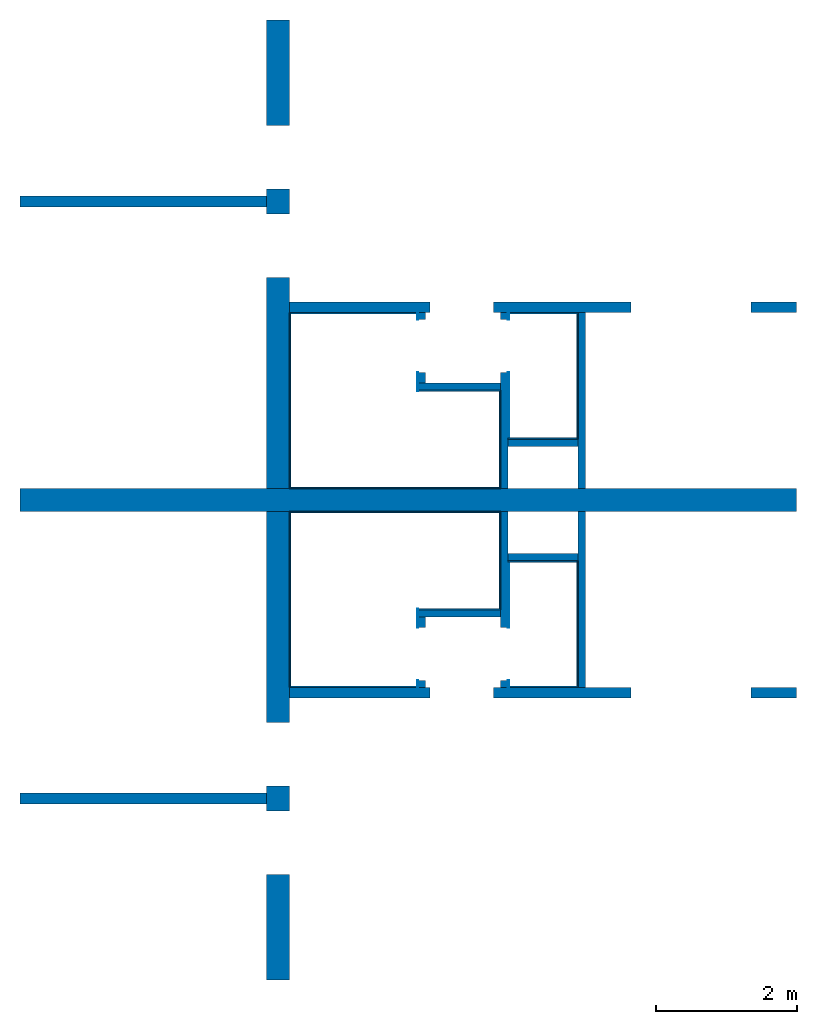
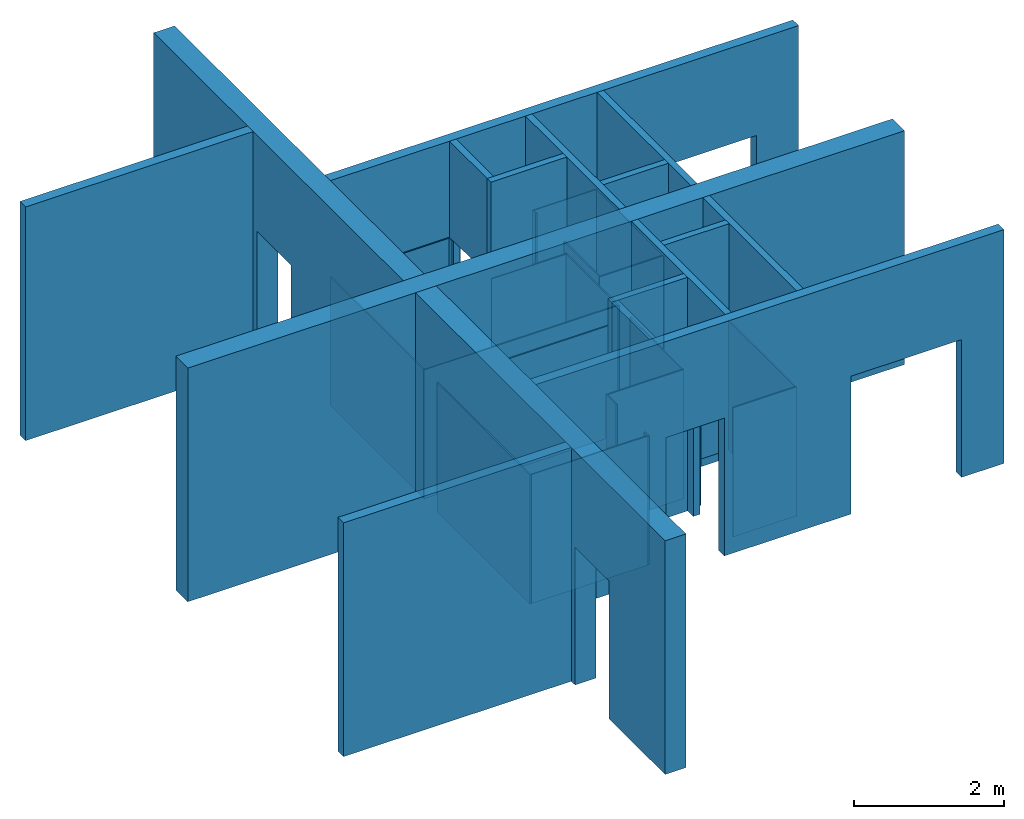
# One storey: 37 walls, 16 openings.
"""IFC2X3 building model written with IfcOpenShell, lengths in millimetres."""

from ifc_helpers import new_model, entity, si_unit, converted_unit, derived_unit, direction, frame, frame_2d, origin, origin_2d_with_axis, place, context, subcontext, project, spatial, rectangle, extrude, material, layer, layer_set, layer_usage, type_object, element, save


model = new_model("IFC2X3")

# Units and contexts
model_context = context("Model", 3, precision=0.01, world=origin(), true_north=direction((6.12303176911189e-17, 1.0)))
body_context = subcontext(model_context, "Body", "Model", "MODEL_VIEW")
ifc_project = project(units=[si_unit("LENGTHUNIT", "METRE", prefix="MILLI"), si_unit("AREAUNIT", "SQUARE_METRE"), si_unit("VOLUMEUNIT", "CUBIC_METRE"), converted_unit("PLANEANGLEUNIT", "DEGREE", entity("IfcRatioMeasure", 0.0174532925199433), si_unit("PLANEANGLEUNIT", "RADIAN"), dimensions=[0, 0, 0, 0, 0, 0, 0]), si_unit("MASSUNIT", "GRAM", prefix="KILO"), derived_unit("MASSDENSITYUNIT", [(si_unit("MASSUNIT", "GRAM", prefix="KILO"), 1), (si_unit("LENGTHUNIT", "METRE"), -3)]), si_unit("TIMEUNIT", "SECOND"), si_unit("FREQUENCYUNIT", "HERTZ"), si_unit("THERMODYNAMICTEMPERATUREUNIT", "DEGREE_CELSIUS"), derived_unit("THERMALTRANSMITTANCEUNIT", [(si_unit("MASSUNIT", "GRAM", prefix="KILO"), 1), (si_unit("THERMODYNAMICTEMPERATUREUNIT", "KELVIN"), -1), (si_unit("TIMEUNIT", "SECOND"), -3)]), derived_unit("VOLUMETRICFLOWRATEUNIT", [(si_unit("LENGTHUNIT", "METRE"), 3), (si_unit("TIMEUNIT", "SECOND"), -1)]), si_unit("ELECTRICCURRENTUNIT", "AMPERE"), si_unit("ELECTRICVOLTAGEUNIT", "VOLT"), si_unit("POWERUNIT", "WATT"), si_unit("FORCEUNIT", "NEWTON", prefix="KILO"), si_unit("ILLUMINANCEUNIT", "LUX"), si_unit("LUMINOUSFLUXUNIT", "LUMEN"), si_unit("LUMINOUSINTENSITYUNIT", "CANDELA"), derived_unit("USERDEFINED", [(si_unit("MASSUNIT", "GRAM", prefix="KILO"), -1), (si_unit("LENGTHUNIT", "METRE"), -2), (si_unit("TIMEUNIT", "SECOND"), 3), (si_unit("LUMINOUSFLUXUNIT", "LUMEN"), 1)]), derived_unit("LINEARVELOCITYUNIT", [(si_unit("LENGTHUNIT", "METRE"), 1), (si_unit("TIMEUNIT", "SECOND"), -1)]), si_unit("PRESSUREUNIT", "PASCAL"), derived_unit("USERDEFINED", [(si_unit("LENGTHUNIT", "METRE"), -2), (si_unit("MASSUNIT", "GRAM", prefix="KILO"), 1), (si_unit("TIMEUNIT", "SECOND"), -2)])], contexts=[model_context])

# Site, building, storey
site_placement = place(None, origin())
site = spatial("IfcSite", under=ifc_project, at=site_placement, CompositionType="ELEMENT")
building_placement = place(site_placement, origin())
building = spatial("IfcBuilding", under=site, at=building_placement, CompositionType="ELEMENT")
storey_placement = place(building_placement, frame((0.0, 0.0, 4000.0)))
storey = spatial("IfcBuildingStorey", under=building, at=storey_placement, Name="01 Level", CompositionType="ELEMENT", Elevation=4000.0)

# Wall
ifc_material_1 = material(Name="03")
ifc_layer_1 = layer(ifc_material_1, 12.5)
ifc_layer_2 = layer(ifc_material_1, 12.5)
ifc_material_2 = material(Name="04_Akustik Board")
ifc_layer_3 = layer(ifc_material_2, 100.0)
ifc_layer_4 = layer(ifc_material_1, 12.5)
ifc_layer_5 = layer(ifc_material_1, 12.5)
ifc_layer_set_1 = layer_set([ifc_layer_1, ifc_layer_2, ifc_layer_3, ifc_layer_4, ifc_layer_5], Name="Basic Wall:01_fal 150 mm - 2")
ifc_layer_usage_1 = layer_usage(ifc_layer_set_1, "AXIS2", "NEGATIVE", 75.0)
wall_type_1 = type_object("IfcWallType", Name="Basic Wall:01_fal 150 mm - 2", PredefinedType="STANDARD", material=ifc_layer_set_1)
wall_1_placement = place(storey_placement, frame((17483.4900708518, -73066.2395851399, -140.0)))
element("IfcWallStandardCase", 1, at=wall_1_placement, inside=storey, type_object=wall_type_1, material=ifc_layer_usage_1, Name="Basic Wall:01_fal 150 mm - 2", ObjectType="Basic Wall:01_fal 150 mm - 2", context=body_context, shape_type="SweptSolid", body=[
    extrude(rectangle(XDim=3500.00000000001, YDim=150.000000000001, at=frame_2d((1750.00000000001, 6.46593889541691e-13), x_axis=(-1.0, 0.0))), origin(), (0.0, 0.0, 1.0), 3800.0),
])

# Wall, openings
ifc_layer_usage_2 = layer_usage(ifc_layer_set_1, "AXIS2", "NEGATIVE", 75.0)
wall_2_placement = place(storey_placement, frame((21303.4900708518, -71566.2395851399, -140.0)))
wall_2 = element("IfcWallStandardCase", 2, at=wall_2_placement, inside=storey, type_object=wall_type_1, material=ifc_layer_usage_2, Name="Basic Wall:01_fal 150 mm - 2", ObjectType="Basic Wall:01_fal 150 mm - 2", context=body_context, shape_type="SweptSolid", body=[
    extrude(rectangle(XDim=7200.0, YDim=150.000000000001, at=frame_2d((3600.0, 1.81898940354586e-12), x_axis=(-1.0, 0.0))), origin(), (0.0, 0.0, 1.0), 3800.0),
])
opening_1_placement = place(wall_2_placement, frame((4850.0, -75.0, 0.0)))
element("IfcOpeningElement", 3, at=opening_1_placement, cuts=wall_2, Name="Basic Wall:01_fal 150 mm - 2", ObjectType="Opening", context=body_context, shape_type="SweptSolid", body=[
    extrude(rectangle(XDim=2240.0, YDim=1700.0, at=frame_2d((0.0, -2.1600499167107e-12), x_axis=(1.0, 0.0))), frame((850.0, 0.0, 1120.0), z_axis=(0.0, 1.0, 0.0), x_axis=(0.0, 0.0, -1.0)), (0.0, 0.0, 1.0), 150.000000000001),
])
opening_2_placement = place(wall_2_placement, frame((2000.0, -1449.0, 0.0)))
element("IfcOpeningElement", 4, at=opening_2_placement, cuts=wall_2, Name="Basic Wall:01_fal 150 mm - 2", ObjectType="Opening", context=body_context, shape_type="SweptSolid", body=[
    extrude(rectangle(XDim=2240.0, YDim=900.000000000003, at=frame_2d((-2.1600499167107e-12, 0.0), x_axis=(0.0, 1.0))), frame((450.0, 0.0, 1120.0), z_axis=(0.0, 1.0, 0.0), x_axis=(-1.0, 0.0, 0.0)), (0.0, 0.0, 1.0), 3048.0),
])

# Wall
ifc_layer_usage_3 = layer_usage(ifc_layer_set_1, "AXIS2", "POSITIVE", -75.0)
wall_3_placement = place(storey_placement, frame((17483.4900708518, -64596.2395851399, -140.0)))
element("IfcWallStandardCase", 5, at=wall_3_placement, inside=storey, type_object=wall_type_1, material=ifc_layer_usage_3, Name="Basic Wall:01_fal 150 mm - 2", ObjectType="Basic Wall:01_fal 150 mm - 2", context=body_context, shape_type="SweptSolid", body=[
    extrude(rectangle(XDim=3500.00000000003, YDim=150.000000000001, at=frame_2d((1750.00000000002, 1.27897692436818e-12), x_axis=(-1.0, 0.0))), origin(), (0.0, 0.0, 1.0), 3800.0),
])

# Wall, openings
ifc_layer_usage_4 = layer_usage(ifc_layer_set_1, "AXIS2", "POSITIVE", -75.0)
wall_4_placement = place(storey_placement, frame((21303.4900708518, -66096.2395851399, -140.0)))
wall_4 = element("IfcWallStandardCase", 6, at=wall_4_placement, inside=storey, type_object=wall_type_1, material=ifc_layer_usage_4, Name="Basic Wall:01_fal 150 mm - 2", ObjectType="Basic Wall:01_fal 150 mm - 2", context=body_context, shape_type="SweptSolid", body=[
    extrude(rectangle(XDim=7199.99999999998, YDim=150.000000000001, at=frame_2d((3599.99999999999, -1.69819713846664e-12), x_axis=(-1.0, 0.0))), origin(), (0.0, 0.0, 1.0), 3800.0),
])
opening_3_placement = place(wall_4_placement, frame((4850.0, -75.0, 0.0)))
element("IfcOpeningElement", 7, at=opening_3_placement, cuts=wall_4, Name="Basic Wall:01_fal 150 mm - 2", ObjectType="Opening", context=body_context, shape_type="SweptSolid", body=[
    extrude(rectangle(XDim=2240.0, YDim=1700.0, at=frame_2d((0.0, -2.1600499167107e-12), x_axis=(1.0, 0.0))), frame((850.0, 0.0, 1120.0), z_axis=(0.0, 1.0, 0.0), x_axis=(0.0, 0.0, -1.0)), (0.0, 0.0, 1.0), 150.000000000001),
])
opening_4_placement = place(wall_4_placement, frame((2000.0, -1599.0, 0.0)))
element("IfcOpeningElement", 8, at=opening_4_placement, cuts=wall_4, Name="Basic Wall:01_fal 150 mm - 2", ObjectType="Opening", context=body_context, shape_type="SweptSolid", body=[
    extrude(rectangle(XDim=2240.0, YDim=900.000000000003, at=frame_2d((-2.1600499167107e-12, 0.0), x_axis=(0.0, 1.0))), frame((450.0, 0.0, 1120.0), z_axis=(0.0, 1.0, 0.0), x_axis=(-1.0, 0.0, 0.0)), (0.0, 0.0, 1.0), 3048.0),
])

ifc_material_3 = material(Name="03")
ifc_layer_6 = layer(ifc_material_3, 10.0)
ifc_material_4 = material()
ifc_layer_7 = layer(ifc_material_4, 300.0)
ifc_layer_8 = layer(ifc_material_3, 10.0)
ifc_layer_set_2 = layer_set([ifc_layer_6, ifc_layer_7, ifc_layer_8], Name="Basic Wall:01_fal 300 mm")
ifc_layer_usage_5 = layer_usage(ifc_layer_set_2, "AXIS2", "NEGATIVE", 160.0)
wall_type_2 = type_object("IfcWallType", Name="Basic Wall:01_fal 300 mm", PredefinedType="STANDARD", material=ifc_layer_set_2)
wall_5_placement = place(storey_placement, frame((21143.4900708518, -68991.2395851399, -140.0), z_axis=(0.0, 0.0, 1.0), x_axis=(0.0, -1.0, 0.0)))
wall_5 = element("IfcWallStandardCase", 9, at=wall_5_placement, inside=storey, type_object=wall_type_2, material=ifc_layer_usage_5, Name="Basic Wall:01_fal 300 mm", ObjectType="Basic Wall:01_fal 300 mm", context=body_context, shape_type="SweptSolid", body=[
    extrude(rectangle(XDim=6650.0, YDim=319.999999999997, at=frame_2d((3325.0, -3.83693077310454e-13), x_axis=(-1.0, 0.0))), origin(), (0.0, 0.0, 1.0), 3800.0),
])
opening_5_placement = place(wall_5_placement, frame((3900.0, -1364.0, 0.0), z_axis=(0.0, 0.0, 1.0), x_axis=(0.0, 1.0, 0.0)))
element("IfcOpeningElement", 10, at=opening_5_placement, cuts=wall_5, Name="Basic Wall:01_fal 300 mm", ObjectType="Opening", context=body_context, shape_type="SweptSolid", body=[
    extrude(rectangle(XDim=2240.0, YDim=900.000000000003, at=origin_2d_with_axis()), frame((0.0, 450.0, 1120.0), z_axis=(1.0, 0.0, 0.0), x_axis=(0.0, 0.0, 1.0)), (0.0, 0.0, 1.0), 3048.0),
])
opening_6_placement = place(wall_5_placement, frame((5150.0, -1364.0, 0.0), z_axis=(0.0, 0.0, 1.0), x_axis=(0.0, 1.0, 0.0)))
element("IfcOpeningElement", 11, at=opening_6_placement, cuts=wall_5, Name="Basic Wall:01_fal 300 mm", ObjectType="Opening", context=body_context, shape_type="SweptSolid", body=[
    extrude(rectangle(XDim=2240.0, YDim=900.000000000003, at=frame_2d((0.0, 0.0), x_axis=(0.0, 1.0))), frame((0.0, 450.0, 1120.0), z_axis=(1.0, 0.0, 0.0), x_axis=(0.0, 1.0, 0.0)), (0.0, 0.0, 1.0), 3048.0),
])

# Wall
ifc_layer_usage_6 = layer_usage(ifc_layer_set_2, "AXIS2", "NEGATIVE", 160.0)
wall_6_placement = place(storey_placement, frame((17483.4900708518, -68831.2395851399, -140.0)))
element("IfcWallStandardCase", 12, at=wall_6_placement, inside=storey, type_object=wall_type_2, material=ifc_layer_usage_6, Name="Basic Wall:01_fal 300 mm", ObjectType="Basic Wall:01_fal 300 mm", context=body_context, shape_type="SweptSolid", body=[
    extrude(rectangle(XDim=11020.0, YDim=319.999999999997, at=frame_2d((5510.00000000001, -3.12638803734444e-13), x_axis=(-1.0, 0.0))), origin(), (0.0, 0.0, 1.0), 3800.0),
])

# Wall, openings
ifc_layer_usage_7 = layer_usage(ifc_layer_set_2, "AXIS2", "POSITIVE", -160.0)
wall_7_placement = place(storey_placement, frame((21143.4900708518, -68671.2395851399, -140.0), z_axis=(0.0, 0.0, 1.0), x_axis=(0.0, 1.0, 0.0)))
wall_7 = element("IfcWallStandardCase", 13, at=wall_7_placement, inside=storey, type_object=wall_type_2, material=ifc_layer_usage_7, Name="Basic Wall:01_fal 300 mm", ObjectType="Basic Wall:01_fal 300 mm", context=body_context, shape_type="SweptSolid", body=[
    extrude(rectangle(XDim=6649.99999999998, YDim=319.999999999997, at=frame_2d((3324.99999999999, 1.00897068477934e-12), x_axis=(-1.0, 0.0))), origin(), (0.0, 0.0, 1.0), 3800.0),
])
opening_7_placement = place(wall_7_placement, frame((3000.0, 1364.0, 0.0), z_axis=(0.0, 0.0, 1.0), x_axis=(0.0, -1.0, 0.0)))
element("IfcOpeningElement", 14, at=opening_7_placement, cuts=wall_7, Name="Basic Wall:01_fal 300 mm", ObjectType="Opening", context=body_context, shape_type="SweptSolid", body=[
    extrude(rectangle(XDim=2240.0, YDim=900.000000000003, at=origin_2d_with_axis()), frame((3048.0, 450.0, 1120.0), z_axis=(-1.0, 0.0, 0.0), x_axis=(0.0, 0.0, 1.0)), (0.0, 0.0, 1.0), 3048.0),
])
opening_8_placement = place(wall_7_placement, frame((4250.0, 1364.0, 0.0), z_axis=(0.0, 0.0, 1.0), x_axis=(0.0, -1.0, 0.0)))
element("IfcOpeningElement", 15, at=opening_8_placement, cuts=wall_7, Name="Basic Wall:01_fal 300 mm", ObjectType="Opening", context=body_context, shape_type="SweptSolid", body=[
    extrude(rectangle(XDim=2240.0, YDim=900.000000000003, at=frame_2d((0.0, 0.0), x_axis=(0.0, 1.0))), frame((3048.0, 450.0, 1120.0), z_axis=(-1.0, 0.0, 0.0), x_axis=(0.0, -1.0, 0.0)), (0.0, 0.0, 1.0), 3048.0),
])

# Wall, opening
ifc_layer_9 = layer(ifc_material_1, 12.5)
ifc_layer_10 = layer(ifc_material_2, 75.0)
ifc_layer_11 = layer(ifc_material_1, 12.5)
ifc_layer_set_3 = layer_set([ifc_layer_9, ifc_layer_10, ifc_layer_11], Name="Basic Wall:01_fal 100 mm - 1")
ifc_layer_usage_8 = layer_usage(ifc_layer_set_3, "AXIS2", "NEGATIVE", 50.0)
wall_type_3 = type_object("IfcWallType", Name="Basic Wall:01_fal 100 mm - 1", PredefinedType="STANDARD", material=ifc_layer_set_3)
wall_8_placement = place(storey_placement, frame((24353.4900708518, -71491.2395851399, -140.0), z_axis=(0.0, 0.0, 1.0), x_axis=(0.0, 1.0, 0.0)))
wall_8 = element("IfcWallStandardCase", 16, at=wall_8_placement, inside=storey, type_object=wall_type_3, material=ifc_layer_usage_8, Name="Basic Wall:01_fal 100 mm - 1", ObjectType="Basic Wall:01_fal 100 mm - 1", context=body_context, shape_type="SweptSolid", body=[
    extrude(rectangle(XDim=2499.99999999999, YDim=100.000000000003, at=frame_2d((1250.0, 2.66453525910038e-13), x_axis=(-1.0, 0.0))), origin(), (0.0, 0.0, 1.0), 3800.0),
])
opening_9_placement = place(wall_8_placement, frame((100.0, 1574.0, 0.0), z_axis=(0.0, 0.0, 1.0), x_axis=(0.0, -1.0, 0.0)))
element("IfcOpeningElement", 17, at=opening_9_placement, cuts=wall_8, Name="Basic Wall:01_fal 100 mm - 1", ObjectType="Opening", context=body_context, shape_type="SweptSolid", body=[
    extrude(rectangle(XDim=2240.0, YDim=750.000000000003, at=frame_2d((0.0, 0.0), x_axis=(0.0, 1.0))), frame((3048.0, 375.0, 1120.0), z_axis=(-1.0, 0.0, 0.0), x_axis=(0.0, -1.0, 0.0)), (0.0, 0.0, 1.0), 3048.0),
])

# Walls
ifc_layer_usage_9 = layer_usage(ifc_layer_set_3, "AXIS2", "NEGATIVE", 50.0)
wall_9_placement = place(storey_placement, frame((25453.4900708518, -71491.2395851399, -140.0), z_axis=(0.0, 0.0, 1.0), x_axis=(0.0, 1.0, 0.0)))
element("IfcWallStandardCase", 18, at=wall_9_placement, inside=storey, type_object=wall_type_3, material=ifc_layer_usage_9, Name="Basic Wall:01_fal 100 mm - 1", ObjectType="Basic Wall:01_fal 100 mm - 1", context=body_context, shape_type="SweptSolid", body=[
    extrude(rectangle(XDim=2499.99999999999, YDim=100.000000000003, at=frame_2d((1249.99999999999, 2.66453525910038e-13), x_axis=(-1.0, 0.0))), origin(), (0.0, 0.0, 1.0), 3800.0),
])
ifc_layer_usage_10 = layer_usage(ifc_layer_set_3, "AXIS2", "NEGATIVE", 50.0)
wall_10_placement = place(storey_placement, frame((24403.4900708518, -69641.2395851399, -140.0)))
element("IfcWallStandardCase", 19, at=wall_10_placement, inside=storey, type_object=wall_type_3, material=ifc_layer_usage_10, Name="Basic Wall:01_fal 100 mm - 1", ObjectType="Basic Wall:01_fal 100 mm - 1", context=body_context, shape_type="SweptSolid", body=[
    extrude(rectangle(XDim=1000.0, YDim=99.9999999999946, at=frame_2d((500.000000000001, 0.0), x_axis=(-1.0, 0.0))), origin(), (0.0, 0.0, 1.0), 3800.0),
])

# Wall, opening
ifc_layer_usage_11 = layer_usage(ifc_layer_set_3, "AXIS2", "POSITIVE", -50.0)
wall_11_placement = place(storey_placement, frame((24353.4900708518, -66171.2395851399, -140.0), z_axis=(0.0, 0.0, 1.0), x_axis=(0.0, -1.0, 0.0)))
wall_11 = element("IfcWallStandardCase", 20, at=wall_11_placement, inside=storey, type_object=wall_type_3, material=ifc_layer_usage_11, Name="Basic Wall:01_fal 100 mm - 1", ObjectType="Basic Wall:01_fal 100 mm - 1", context=body_context, shape_type="SweptSolid", body=[
    extrude(rectangle(XDim=2499.99999999998, YDim=100.000000000003, at=frame_2d((1249.99999999999, 7.95807864051312e-13), x_axis=(-1.0, 0.0))), origin(), (0.0, 0.0, 1.0), 3800.0),
])
opening_10_placement = place(wall_11_placement, frame((850.0, -1574.0, 0.0), z_axis=(0.0, 0.0, 1.0), x_axis=(0.0, 1.0, 0.0)))
element("IfcOpeningElement", 21, at=opening_10_placement, cuts=wall_11, Name="Basic Wall:01_fal 100 mm - 1", ObjectType="Opening", context=body_context, shape_type="SweptSolid", body=[
    extrude(rectangle(XDim=2240.0, YDim=750.000000000003, at=frame_2d((0.0, 0.0), x_axis=(0.0, 1.0))), frame((0.0, 375.0, 1120.0), z_axis=(1.0, 0.0, 0.0), x_axis=(0.0, 1.0, 0.0)), (0.0, 0.0, 1.0), 3048.0),
])

# Walls
ifc_layer_usage_12 = layer_usage(ifc_layer_set_3, "AXIS2", "POSITIVE", -50.0)
wall_12_placement = place(storey_placement, frame((25453.4900708518, -66171.2395851399, -140.0), z_axis=(0.0, 0.0, 1.0), x_axis=(0.0, -1.0, 0.0)))
element("IfcWallStandardCase", 22, at=wall_12_placement, inside=storey, type_object=wall_type_3, material=ifc_layer_usage_12, Name="Basic Wall:01_fal 100 mm - 1", ObjectType="Basic Wall:01_fal 100 mm - 1", context=body_context, shape_type="SweptSolid", body=[
    extrude(rectangle(XDim=2499.99999999999, YDim=100.000000000003, at=frame_2d((1249.99999999999, 7.95807864051312e-13), x_axis=(-1.0, 0.0))), origin(), (0.0, 0.0, 1.0), 3800.0),
])
ifc_layer_usage_13 = layer_usage(ifc_layer_set_3, "AXIS2", "POSITIVE", -50.0)
wall_13_placement = place(storey_placement, frame((24403.4900708518, -68021.2395851399, -140.0)))
element("IfcWallStandardCase", 23, at=wall_13_placement, inside=storey, type_object=wall_type_3, material=ifc_layer_usage_13, Name="Basic Wall:01_fal 100 mm - 1", ObjectType="Basic Wall:01_fal 100 mm - 1", context=body_context, shape_type="SweptSolid", body=[
    extrude(rectangle(XDim=1000.0, YDim=99.9999999999946, at=frame_2d((500.000000000001, -1.30384592011978e-12), x_axis=(-1.0, 0.0))), origin(), (0.0, 0.0, 1.0), 3800.0),
])
ifc_layer_usage_14 = layer_usage(ifc_layer_set_3, "AXIS2", "NEGATIVE", 50.0)
wall_14_placement = place(storey_placement, frame((24303.4900708518, -70441.2395851399, -140.0), z_axis=(0.0, 0.0, 1.0), x_axis=(-1.0, 0.0, 0.0)))
element("IfcWallStandardCase", 24, at=wall_14_placement, inside=storey, type_object=wall_type_3, material=ifc_layer_usage_14, Name="Basic Wall:01_fal 100 mm - 1", ObjectType="Basic Wall:01_fal 100 mm - 1", context=body_context, shape_type="SweptSolid", body=[
    extrude(rectangle(XDim=1167.5, YDim=99.9999999999946, at=frame_2d((583.749999999999, 0.0), x_axis=(-1.0, 0.0))), origin(), (0.0, 0.0, 1.0), 3800.0),
])

# Wall, opening
ifc_layer_usage_15 = layer_usage(ifc_layer_set_3, "AXIS2", "NEGATIVE", 50.0)
wall_15_placement = place(storey_placement, frame((23185.9900708518, -70491.2395851399, -140.0), z_axis=(0.0, 0.0, 1.0), x_axis=(0.0, -1.0, 0.0)))
wall_15 = element("IfcWallStandardCase", 25, at=wall_15_placement, inside=storey, type_object=wall_type_3, material=ifc_layer_usage_15, Name="Basic Wall:01_fal 100 mm - 1", ObjectType="Basic Wall:01_fal 100 mm - 1", context=body_context, shape_type="SweptSolid", body=[
    extrude(rectangle(XDim=999.999999999981, YDim=100.000000000003, at=frame_2d((499.99999999999, 0.0), x_axis=(-1.0, 0.0))), origin(), (0.0, 0.0, 1.0), 3800.0),
])
opening_11_placement = place(wall_15_placement, frame((900.0, -1474.0, 0.0), z_axis=(0.0, 0.0, 1.0), x_axis=(0.0, 1.0, 0.0)))
element("IfcOpeningElement", 26, at=opening_11_placement, cuts=wall_15, Name="Basic Wall:01_fal 100 mm - 1", ObjectType="Opening", context=body_context, shape_type="SweptSolid", body=[
    extrude(rectangle(XDim=2240.0, YDim=750.000000000003, at=origin_2d_with_axis()), frame((0.0, 375.0, 1120.0), z_axis=(1.0, 0.0, 0.0), x_axis=(0.0, 0.0, 1.0)), (0.0, 0.0, 1.0), 3048.0),
])

# Wall
ifc_layer_usage_16 = layer_usage(ifc_layer_set_3, "AXIS2", "POSITIVE", -50.0)
wall_16_placement = place(storey_placement, frame((24303.4900708518, -67221.2395851399, -140.0), z_axis=(0.0, 0.0, 1.0), x_axis=(-1.0, 0.0, 0.0)))
element("IfcWallStandardCase", 27, at=wall_16_placement, inside=storey, type_object=wall_type_3, material=ifc_layer_usage_16, Name="Basic Wall:01_fal 100 mm - 1", ObjectType="Basic Wall:01_fal 100 mm - 1", context=body_context, shape_type="SweptSolid", body=[
    extrude(rectangle(XDim=1167.50000000001, YDim=99.9999999999946, at=frame_2d((583.750000000004, -7.99360577730113e-13), x_axis=(-1.0, 0.0))), origin(), (0.0, 0.0, 1.0), 3800.0),
])

# Wall, opening
ifc_layer_usage_17 = layer_usage(ifc_layer_set_3, "AXIS2", "POSITIVE", -50.0)
wall_17_placement = place(storey_placement, frame((23185.9900708518, -67171.2395851399, -140.0), z_axis=(0.0, 0.0, 1.0), x_axis=(0.0, 1.0, 0.0)))
wall_17 = element("IfcWallStandardCase", 28, at=wall_17_placement, inside=storey, type_object=wall_type_3, material=ifc_layer_usage_17, Name="Basic Wall:01_fal 100 mm - 1", ObjectType="Basic Wall:01_fal 100 mm - 1", context=body_context, shape_type="SweptSolid", body=[
    extrude(rectangle(XDim=999.999999999955, YDim=100.000000000003, at=frame_2d((499.999999999977, -1.30739863379858e-12), x_axis=(-1.0, 0.0))), origin(), (0.0, 0.0, 1.0), 3800.0),
])
opening_12_placement = place(wall_17_placement, frame((150.0, 1474.0, 0.0), z_axis=(0.0, 0.0, 1.0), x_axis=(0.0, -1.0, 0.0)))
element("IfcOpeningElement", 29, at=opening_12_placement, cuts=wall_17, Name="Basic Wall:01_fal 100 mm - 1", ObjectType="Opening", context=body_context, shape_type="SweptSolid", body=[
    extrude(rectangle(XDim=2240.0, YDim=750.000000000003, at=origin_2d_with_axis()), frame((3048.0, 375.0, 1120.0), z_axis=(-1.0, 0.0, 0.0), x_axis=(0.0, 0.0, 1.0)), (0.0, 0.0, 1.0), 3048.0),
])

ifc_material_5 = material(Name="07")
ifc_layer_12 = layer(ifc_material_5, 15.0)
ifc_material_6 = material(Name="06")
ifc_layer_13 = layer(ifc_material_6, 5.0)
ifc_layer_set_4 = layer_set([ifc_layer_12, ifc_layer_13], Name="Basic Wall:01")
ifc_layer_usage_18 = layer_usage(ifc_layer_set_4, "AXIS2", "NEGATIVE", 10.0)
wall_type_4 = type_object("IfcWallType", Name="Basic Wall:01", PredefinedType="STANDARD", material=ifc_layer_set_4)
wall_18_placement = place(storey_placement, frame((23125.9900708518, -71491.2395851399, 0.0), z_axis=(0.0, 0.0, 1.0), x_axis=(0.0, 1.0, 0.0)))
wall_18 = element("IfcWallStandardCase", 30, at=wall_18_placement, inside=storey, type_object=wall_type_4, material=ifc_layer_usage_18, Name="Basic Wall:01", ObjectType="Basic Wall:01", context=body_context, shape_type="SweptSolid", body=[
    extrude(rectangle(XDim=1119.99999999999, YDim=20.0000000000041, at=frame_2d((559.999999999994, 0.0), x_axis=(-1.0, 0.0))), origin(), (0.0, 0.0, 1.0), 2100.0),
])
opening_13_placement = place(wall_18_placement, frame((100.0, 1414.0, -140.0)))
element("IfcOpeningElement", 31, at=opening_13_placement, cuts=wall_18, Name="Basic Wall:01", ObjectType="Opening", context=body_context, shape_type="SweptSolid", body=[
    extrude(rectangle(XDim=2240.0, YDim=750.000000000003, at=frame_2d((0.0, 0.0), x_axis=(0.0, 1.0))), frame((375.0, -3048.0, 1120.0), z_axis=(0.0, 1.0, 0.0), x_axis=(-1.0, 0.0, 0.0)), (0.0, 0.0, 1.0), 3048.0),
])

# Walls
ifc_layer_usage_19 = layer_usage(ifc_layer_set_4, "AXIS2", "NEGATIVE", 10.0)
wall_19_placement = place(storey_placement, frame((23135.9900708518, -70381.2395851399, 0.0)))
element("IfcWallStandardCase", 32, at=wall_19_placement, inside=storey, type_object=wall_type_4, material=ifc_layer_usage_19, Name="Basic Wall:01", ObjectType="Basic Wall:01", context=body_context, shape_type="SweptSolid", body=[
    extrude(rectangle(XDim=1167.49999999999, YDim=19.9999999999955, at=frame_2d((583.749999999997, 0.0), x_axis=(-1.0, 0.0))), origin(), (0.0, 0.0, 1.0), 2100.0),
])
ifc_layer_usage_20 = layer_usage(ifc_layer_set_4, "AXIS2", "NEGATIVE", 10.0)
wall_20_placement = place(storey_placement, frame((24293.4900708518, -70371.2395851399, 0.0), z_axis=(0.0, 0.0, 1.0), x_axis=(0.0, 1.0, 0.0)))
element("IfcWallStandardCase", 33, at=wall_20_placement, inside=storey, type_object=wall_type_4, material=ifc_layer_usage_20, Name="Basic Wall:01", ObjectType="Basic Wall:01", context=body_context, shape_type="SweptSolid", body=[
    extrude(rectangle(XDim=1380.0, YDim=20.0000000000041, at=frame_2d((689.999999999999, 0.0), x_axis=(-1.0, 0.0))), origin(), (0.0, 0.0, 1.0), 2100.0),
])
ifc_layer_usage_21 = layer_usage(ifc_layer_set_4, "AXIS2", "NEGATIVE", 10.0)
wall_21_placement = place(storey_placement, frame((24283.4900708518, -69001.2395851399, 0.0), z_axis=(0.0, 0.0, 1.0), x_axis=(-1.0, 0.0, 0.0)))
element("IfcWallStandardCase", 34, at=wall_21_placement, inside=storey, type_object=wall_type_4, material=ifc_layer_usage_21, Name="Basic Wall:01", ObjectType="Basic Wall:01", context=body_context, shape_type="SweptSolid", body=[
    extrude(rectangle(XDim=2979.99999999999, YDim=19.9999999999955, at=frame_2d((1490.0, 1.3855583347322e-13), x_axis=(-1.0, 0.0))), origin(), (0.0, 0.0, 1.0), 2100.0),
])
ifc_layer_usage_22 = layer_usage(ifc_layer_set_4, "AXIS2", "NEGATIVE", 10.0)
wall_22_placement = place(storey_placement, frame((21313.4900708518, -69011.2395851399, 0.0), z_axis=(0.0, 0.0, 1.0), x_axis=(0.0, -1.0, 0.0)))
element("IfcWallStandardCase", 35, at=wall_22_placement, inside=storey, type_object=wall_type_4, material=ifc_layer_usage_22, Name="Basic Wall:01", ObjectType="Basic Wall:01", context=body_context, shape_type="SweptSolid", body=[
    extrude(rectangle(XDim=2479.99999999998, YDim=20.0000000000041, at=frame_2d((1239.99999999999, 9.68114477473137e-14), x_axis=(-1.0, 0.0))), origin(), (0.0, 0.0, 1.0), 2100.0),
])
ifc_layer_usage_23 = layer_usage(ifc_layer_set_4, "AXIS2", "NEGATIVE", 10.0)
wall_23_placement = place(storey_placement, frame((21323.4900708518, -71481.2395851399, 0.0)))
element("IfcWallStandardCase", 36, at=wall_23_placement, inside=storey, type_object=wall_type_4, material=ifc_layer_usage_23, Name="Basic Wall:01", ObjectType="Basic Wall:01", context=body_context, shape_type="SweptSolid", body=[
    extrude(rectangle(XDim=1792.5, YDim=19.9999999999955, at=frame_2d((896.250000000002, 1.82964754458226e-13), x_axis=(-1.0, 0.0))), origin(), (0.0, 0.0, 1.0), 2100.0),
])

# Wall, opening
ifc_layer_usage_24 = layer_usage(ifc_layer_set_4, "AXIS2", "POSITIVE", -10.0)
wall_24_placement = place(storey_placement, frame((23125.9900708518, -66171.2395851399, 0.0), z_axis=(0.0, 0.0, 1.0), x_axis=(0.0, -1.0, 0.0)))
wall_24 = element("IfcWallStandardCase", 37, at=wall_24_placement, inside=storey, type_object=wall_type_4, material=ifc_layer_usage_24, Name="Basic Wall:01", ObjectType="Basic Wall:01", context=body_context, shape_type="SweptSolid", body=[
    extrude(rectangle(XDim=1120.0, YDim=20.0000000000041, at=frame_2d((559.999999999998, -9.45910016980633e-13), x_axis=(-1.0, 0.0))), origin(), (0.0, 0.0, 1.0), 2100.0),
])
opening_14_placement = place(wall_24_placement, frame((850.0, -1414.0, -140.0)))
element("IfcOpeningElement", 38, at=opening_14_placement, cuts=wall_24, Name="Basic Wall:01", ObjectType="Opening", context=body_context, shape_type="SweptSolid", body=[
    extrude(rectangle(XDim=2240.0, YDim=750.000000000003, at=frame_2d((0.0, 0.0), x_axis=(0.0, 1.0))), frame((-375.0, 0.0, 1120.0), z_axis=(0.0, 1.0, 0.0), x_axis=(-1.0, 0.0, 0.0)), (0.0, 0.0, 1.0), 3048.0),
])

# Walls
ifc_layer_usage_25 = layer_usage(ifc_layer_set_4, "AXIS2", "POSITIVE", -10.0)
wall_25_placement = place(storey_placement, frame((23135.9900708518, -67281.2395851399, 0.0)))
element("IfcWallStandardCase", 39, at=wall_25_placement, inside=storey, type_object=wall_type_4, material=ifc_layer_usage_25, Name="Basic Wall:01", ObjectType="Basic Wall:01", context=body_context, shape_type="SweptSolid", body=[
    extrude(rectangle(XDim=1167.49999999999, YDim=19.9999999999955, at=frame_2d((583.749999999997, -8.01136934569513e-13), x_axis=(-1.0, 0.0))), origin(), (0.0, 0.0, 1.0), 2100.0),
])
ifc_layer_usage_26 = layer_usage(ifc_layer_set_4, "AXIS2", "POSITIVE", -10.0)
wall_26_placement = place(storey_placement, frame((24293.4900708518, -67291.2395851399, 0.0), z_axis=(0.0, 0.0, 1.0), x_axis=(0.0, -1.0, 0.0)))
element("IfcWallStandardCase", 40, at=wall_26_placement, inside=storey, type_object=wall_type_4, material=ifc_layer_usage_26, Name="Basic Wall:01", ObjectType="Basic Wall:01", context=body_context, shape_type="SweptSolid", body=[
    extrude(rectangle(XDim=1379.99999999997, YDim=20.0000000000041, at=frame_2d((689.999999999986, -1.58983937126322e-13), x_axis=(-1.0, 0.0))), origin(), (0.0, 0.0, 1.0), 2100.0),
])
ifc_layer_usage_27 = layer_usage(ifc_layer_set_4, "AXIS2", "POSITIVE", -10.0)
wall_27_placement = place(storey_placement, frame((24283.4900708518, -68661.2395851399, 0.0), z_axis=(0.0, 0.0, 1.0), x_axis=(-1.0, 0.0, 0.0)))
element("IfcWallStandardCase", 41, at=wall_27_placement, inside=storey, type_object=wall_type_4, material=ifc_layer_usage_27, Name="Basic Wall:01", ObjectType="Basic Wall:01", context=body_context, shape_type="SweptSolid", body=[
    extrude(rectangle(XDim=2980.0, YDim=19.9999999999955, at=frame_2d((1490.0, 2.0961010704923e-13), x_axis=(-1.0, 0.0))), origin(), (0.0, 0.0, 1.0), 2100.0),
])
ifc_layer_usage_28 = layer_usage(ifc_layer_set_4, "AXIS2", "POSITIVE", -10.0)
wall_28_placement = place(storey_placement, frame((21313.4900708518, -68651.2395851399, 0.0), z_axis=(0.0, 0.0, 1.0), x_axis=(0.0, 1.0, 0.0)))
element("IfcWallStandardCase", 42, at=wall_28_placement, inside=storey, type_object=wall_type_4, material=ifc_layer_usage_28, Name="Basic Wall:01", ObjectType="Basic Wall:01", context=body_context, shape_type="SweptSolid", body=[
    extrude(rectangle(XDim=2479.99999999996, YDim=20.0000000000041, at=frame_2d((1239.99999999998, 9.04165631254727e-13), x_axis=(-1.0, 0.0))), origin(), (0.0, 0.0, 1.0), 2100.0),
])
ifc_layer_usage_29 = layer_usage(ifc_layer_set_4, "AXIS2", "POSITIVE", -10.0)
wall_29_placement = place(storey_placement, frame((21323.4900708518, -66181.2395851399, 0.0)))
element("IfcWallStandardCase", 43, at=wall_29_placement, inside=storey, type_object=wall_type_4, material=ifc_layer_usage_29, Name="Basic Wall:01", ObjectType="Basic Wall:01", context=body_context, shape_type="SweptSolid", body=[
    extrude(rectangle(XDim=1792.50000000002, YDim=19.9999999999955, at=frame_2d((896.250000000009, 9.06830166513828e-13), x_axis=(-1.0, 0.0))), origin(), (0.0, 0.0, 1.0), 2100.0),
])
ifc_layer_usage_30 = layer_usage(ifc_layer_set_4, "AXIS2", "POSITIVE", -10.0)
wall_30_placement = place(storey_placement, frame((24403.4900708518, -69701.2395851399, 0.0)))
element("IfcWallStandardCase", 44, at=wall_30_placement, inside=storey, type_object=wall_type_4, material=ifc_layer_usage_30, Name="Basic Wall:01", ObjectType="Basic Wall:01", context=body_context, shape_type="SweptSolid", body=[
    extrude(rectangle(XDim=979.999999999998, YDim=19.9999999999955, at=frame_2d((489.999999999999, 0.0), x_axis=(-1.0, 0.0))), origin(), (0.0, 0.0, 1.0), 2100.0),
])

# Wall, opening
ifc_layer_usage_31 = layer_usage(ifc_layer_set_4, "AXIS2", "POSITIVE", -10.0)
wall_31_placement = place(storey_placement, frame((24413.4900708518, -71491.2395851399, 0.0), z_axis=(0.0, 0.0, 1.0), x_axis=(0.0, 1.0, 0.0)))
wall_31 = element("IfcWallStandardCase", 45, at=wall_31_placement, inside=storey, type_object=wall_type_4, material=ifc_layer_usage_31, Name="Basic Wall:01", ObjectType="Basic Wall:01", context=body_context, shape_type="SweptSolid", body=[
    extrude(rectangle(XDim=1779.99999999998, YDim=20.0000000000041, at=frame_2d((889.999999999988, 0.0), x_axis=(-1.0, 0.0))), origin(), (0.0, 0.0, 1.0), 2100.0),
])
opening_15_placement = place(wall_31_placement, frame((100.0, 1634.0, -140.0)))
element("IfcOpeningElement", 46, at=opening_15_placement, cuts=wall_31, Name="Basic Wall:01", ObjectType="Opening", context=body_context, shape_type="SweptSolid", body=[
    extrude(rectangle(XDim=2240.0, YDim=750.000000000003, at=frame_2d((0.0, 0.0), x_axis=(0.0, 1.0))), frame((375.0, -3048.0, 1120.0), z_axis=(0.0, 1.0, 0.0), x_axis=(-1.0, 0.0, 0.0)), (0.0, 0.0, 1.0), 3048.0),
])

# Walls
ifc_layer_usage_32 = layer_usage(ifc_layer_set_4, "AXIS2", "POSITIVE", -10.0)
wall_32_placement = place(storey_placement, frame((25403.4900708518, -71481.2395851399, 0.0), z_axis=(0.0, 0.0, 1.0), x_axis=(-1.0, 0.0, 0.0)))
element("IfcWallStandardCase", 47, at=wall_32_placement, inside=storey, type_object=wall_type_4, material=ifc_layer_usage_32, Name="Basic Wall:01", ObjectType="Basic Wall:01", context=body_context, shape_type="SweptSolid", body=[
    extrude(rectangle(XDim=979.999999999998, YDim=19.9999999999955, at=frame_2d((489.999999999999, 0.0), x_axis=(-1.0, 0.0))), origin(), (0.0, 0.0, 1.0), 2100.0),
])
ifc_layer_usage_33 = layer_usage(ifc_layer_set_4, "AXIS2", "POSITIVE", -10.0)
wall_33_placement = place(storey_placement, frame((25393.4900708518, -69691.2395851399, 0.0), z_axis=(0.0, 0.0, 1.0), x_axis=(0.0, -1.0, 0.0)))
element("IfcWallStandardCase", 48, at=wall_33_placement, inside=storey, type_object=wall_type_4, material=ifc_layer_usage_33, Name="Basic Wall:01", ObjectType="Basic Wall:01", context=body_context, shape_type="SweptSolid", body=[
    extrude(rectangle(XDim=1779.99999999998, YDim=20.0000000000041, at=frame_2d((889.999999999988, 0.0), x_axis=(-1.0, 0.0))), origin(), (0.0, 0.0, 1.0), 2100.0),
])
ifc_layer_usage_34 = layer_usage(ifc_layer_set_4, "AXIS2", "NEGATIVE", 10.0)
wall_34_placement = place(storey_placement, frame((24403.4900708518, -67961.2395851399, 0.0)))
element("IfcWallStandardCase", 49, at=wall_34_placement, inside=storey, type_object=wall_type_4, material=ifc_layer_usage_34, Name="Basic Wall:01", ObjectType="Basic Wall:01", context=body_context, shape_type="SweptSolid", body=[
    extrude(rectangle(XDim=979.99999999999, YDim=19.9999999999955, at=frame_2d((489.999999999995, -1.36779476633819e-12), x_axis=(-1.0, 0.0))), origin(), (0.0, 0.0, 1.0), 2100.0),
])

# Wall, opening
ifc_layer_usage_35 = layer_usage(ifc_layer_set_4, "AXIS2", "NEGATIVE", 10.0)
wall_35_placement = place(storey_placement, frame((24413.4900708518, -66171.2395851399, 0.0), z_axis=(0.0, 0.0, 1.0), x_axis=(0.0, -1.0, 0.0)))
wall_35 = element("IfcWallStandardCase", 50, at=wall_35_placement, inside=storey, type_object=wall_type_4, material=ifc_layer_usage_35, Name="Basic Wall:01", ObjectType="Basic Wall:01", context=body_context, shape_type="SweptSolid", body=[
    extrude(rectangle(XDim=1780.0, YDim=20.0000000000041, at=frame_2d((890.000000000001, 1.05071507050525e-12), x_axis=(-1.0, 0.0))), origin(), (0.0, 0.0, 1.0), 2100.0),
])
opening_16_placement = place(wall_35_placement, frame((850.0, -1634.0, -140.0)))
element("IfcOpeningElement", 51, at=opening_16_placement, cuts=wall_35, Name="Basic Wall:01", ObjectType="Opening", context=body_context, shape_type="SweptSolid", body=[
    extrude(rectangle(XDim=2240.0, YDim=750.000000000003, at=frame_2d((0.0, 0.0), x_axis=(0.0, 1.0))), frame((-375.0, 0.0, 1120.0), z_axis=(0.0, 1.0, 0.0), x_axis=(-1.0, 0.0, 0.0)), (0.0, 0.0, 1.0), 3048.0),
])

# Walls
ifc_layer_usage_36 = layer_usage(ifc_layer_set_4, "AXIS2", "NEGATIVE", 10.0)
wall_36_placement = place(storey_placement, frame((25403.4900708518, -66181.2395851399, 0.0), z_axis=(0.0, 0.0, 1.0), x_axis=(-1.0, 0.0, 0.0)))
element("IfcWallStandardCase", 52, at=wall_36_placement, inside=storey, type_object=wall_type_4, material=ifc_layer_usage_36, Name="Basic Wall:01", ObjectType="Basic Wall:01", context=body_context, shape_type="SweptSolid", body=[
    extrude(rectangle(XDim=979.99999999999, YDim=19.9999999999955, at=frame_2d((489.999999999995, -1.36779476633819e-12), x_axis=(-1.0, 0.0))), origin(), (0.0, 0.0, 1.0), 2100.0),
])
ifc_layer_usage_37 = layer_usage(ifc_layer_set_4, "AXIS2", "NEGATIVE", 10.0)
wall_37_placement = place(storey_placement, frame((25393.4900708518, -67971.2395851399, 0.0), z_axis=(0.0, 0.0, 1.0), x_axis=(0.0, 1.0, 0.0)))
element("IfcWallStandardCase", 53, at=wall_37_placement, inside=storey, type_object=wall_type_4, material=ifc_layer_usage_37, Name="Basic Wall:01", ObjectType="Basic Wall:01", context=body_context, shape_type="SweptSolid", body=[
    extrude(rectangle(XDim=1780.0, YDim=20.0000000000041, at=frame_2d((890.000000000001, 1.05071507050525e-12), x_axis=(-1.0, 0.0))), origin(), (0.0, 0.0, 1.0), 2100.0),
])

save(model, "model.ifc")
